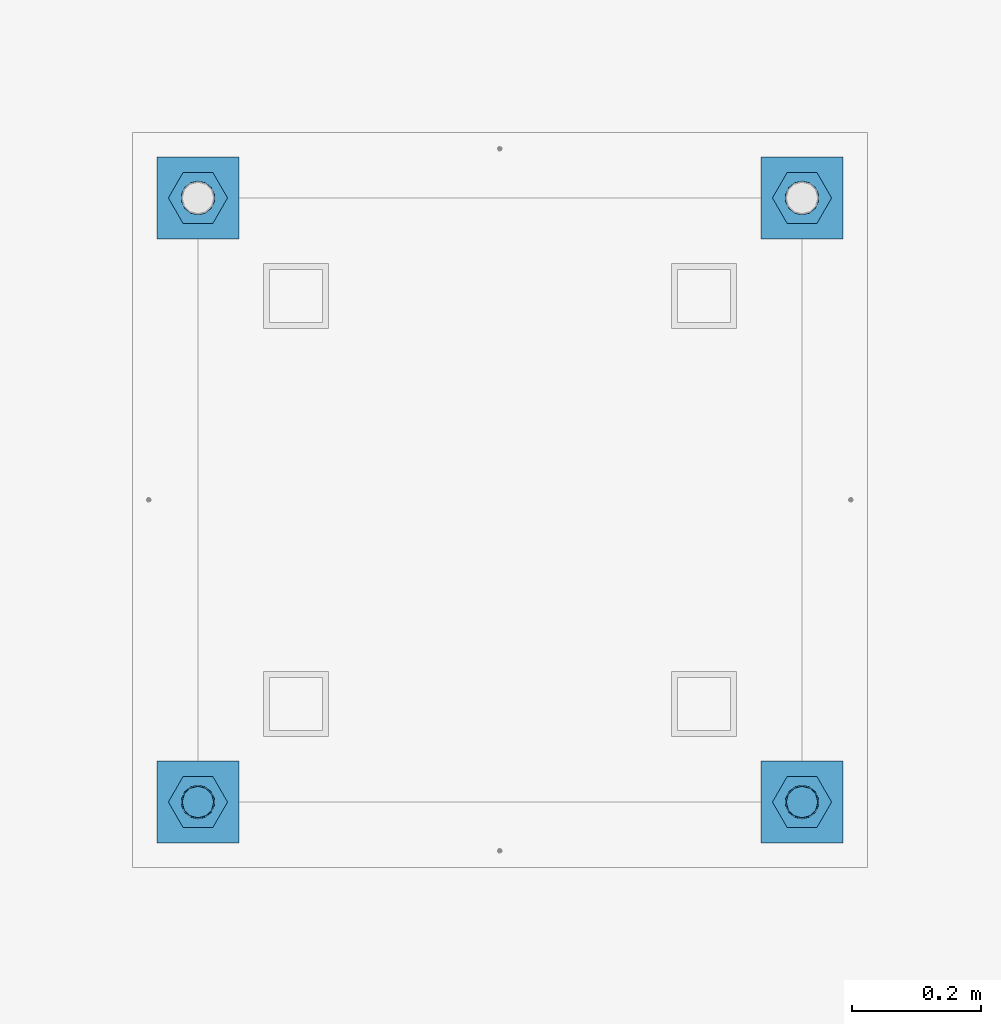
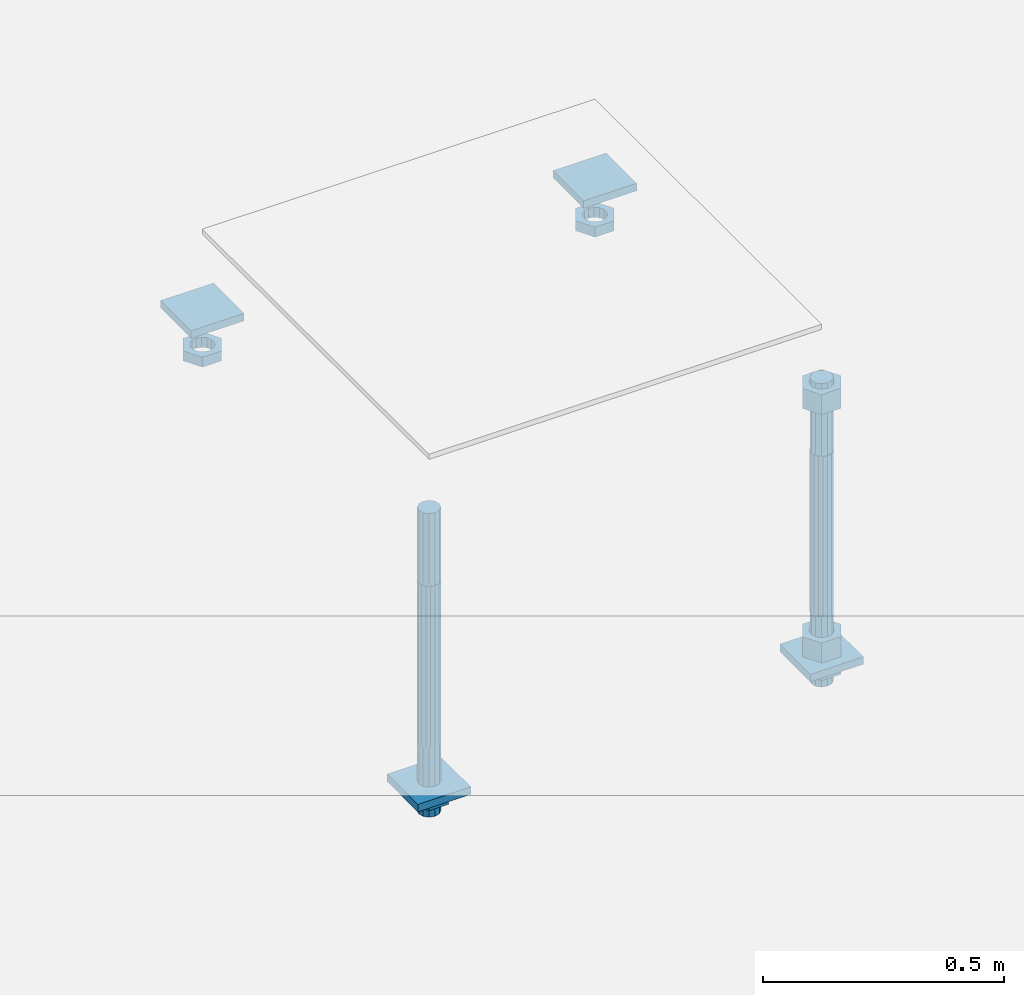
# One storey, part 2582 of 3843: 12 beams, 1 element without a shape of its own.
"""IFC2X3 building model written with IfcOpenShell, lengths in millimetres."""

from ifc_helpers import new_model, si_unit, frame, origin_with_axes, place, context, subcontext, project, spatial, faceted_brep, material, type_object, element, aggregate, save


model = new_model("IFC2X3")

# Units and contexts
model_context = context("Model", 3, precision=1e-05, world=origin_with_axes())
body_context = subcontext(model_context, "Body", "Model", "MODEL_VIEW")
ifc_project = project(units=[si_unit("LENGTHUNIT", "METRE", prefix="MILLI"), si_unit("AREAUNIT", "SQUARE_METRE"), si_unit("VOLUMEUNIT", "CUBIC_METRE"), si_unit("MASSUNIT", "GRAM", prefix="KILO"), si_unit("TIMEUNIT", "SECOND"), si_unit("PLANEANGLEUNIT", "RADIAN"), si_unit("SOLIDANGLEUNIT", "STERADIAN"), si_unit("THERMODYNAMICTEMPERATUREUNIT", "DEGREE_CELSIUS"), si_unit("LUMINOUSINTENSITYUNIT", "LUMEN")], contexts=[model_context])

# Site, building, storey
site_placement = place(None, origin_with_axes())
site = spatial("IfcSite", under=ifc_project, at=site_placement, CompositionType="ELEMENT")
building_placement = place(site_placement, origin_with_axes())
building = spatial("IfcBuilding", under=site, at=building_placement, Name="Undefined", CompositionType="ELEMENT")
storey_placement = place(building_placement, origin_with_axes())
storey = spatial("IfcBuildingStorey", under=building, at=storey_placement, Name="Undefined", CompositionType="ELEMENT", Elevation=0.0)

# Assembly, beams
assembly_placement = place(storey_placement, origin_with_axes())
assembly = element("IfcElementAssembly", 1, at=assembly_placement, inside=storey, Name="TEMPLATE", AssemblyPlace="NOTDEFINED", PredefinedType="RIGID_FRAME")
ifc_material_1 = material(Name="STEEL/A36")
beam_type_1 = type_object("IfcBeamType", PredefinedType="NOTDEFINED")
beam_1_placement = place(assembly_placement, frame((108483.4, 15176.5000015259, 29873.575), z_axis=(1.0, 0.0, 0.0), x_axis=(0.0, 1.0, 0.0)))
beam_1 = element("IfcBeam", 2, at=beam_1_placement, type_object=beam_type_1, material=ifc_material_1, Name="WASHER_PLATE", context=body_context, shape_type="Brep", body=[
    faceted_brep([(0.0, 9.52500000000146, -63.5), (0.0, 9.52500000000146, 63.5), (127.0, 9.52500000000146, 63.5), (127.0, 9.52500000000146, -63.5), (0.0, -9.52500000000146, 63.5), (127.0, -9.52500000000146, 63.5), (0.0, -9.52500000000146, -63.5), (127.0, -9.52500000000146, -63.5)], [[[0, 1, 2, 3]], [[1, 4, 5, 2]], [[4, 6, 7, 5]], [[6, 0, 3, 7]], [[5, 7, 3, 2]], [[6, 4, 1, 0]]]),
])
beam_2_placement = place(assembly_placement, frame((109423.2, 15176.5000015259, 29873.575), z_axis=(1.0, 0.0, 0.0), x_axis=(0.0, 1.0, 0.0)))
beam_2 = element("IfcBeam", 3, at=beam_2_placement, type_object=beam_type_1, material=ifc_material_1, Name="WASHER_PLATE", context=body_context, shape_type="Brep", body=[
    faceted_brep([(0.0, 9.52500000000146, -63.5), (0.0, 9.52500000000146, 63.5), (127.0, 9.52500000000146, 63.5), (127.0, 9.52500000000146, -63.5), (0.0, -9.52500000000146, 63.5), (127.0, -9.52500000000146, 63.5), (0.0, -9.52500000000146, -63.5), (127.0, -9.52500000000146, -63.5)], [[[0, 1, 2, 3]], [[1, 4, 5, 2]], [[4, 6, 7, 5]], [[6, 0, 3, 7]], [[5, 7, 3, 2]], [[6, 4, 1, 0]]]),
])
beam_3_placement = place(assembly_placement, frame((108483.4, 14236.7000015259, 29244.925), z_axis=(1.0, 0.0, 0.0), x_axis=(0.0, 1.0, 0.0)))
beam_3 = element("IfcBeam", 4, at=beam_3_placement, type_object=beam_type_1, material=ifc_material_1, Name="WASHER_PLATE", context=body_context, shape_type="Brep", body=[
    faceted_brep([(0.0, 9.52500000000146, -63.5), (0.0, 9.52500000000146, 63.5), (127.0, 9.52500000000146, 63.5), (127.0, 9.52500000000146, -63.5), (0.0, -9.52500000000146, 63.5), (127.0, -9.52500000000146, 63.5), (0.0, -9.52500000000146, -63.5), (127.0, -9.52500000000146, -63.5)], [[[0, 1, 2, 3]], [[1, 4, 5, 2]], [[4, 6, 7, 5]], [[6, 0, 3, 7]], [[5, 7, 3, 2]], [[6, 4, 1, 0]]]),
])
beam_4_placement = place(assembly_placement, frame((109423.2, 14236.7000015259, 29244.925), z_axis=(1.0, 0.0, 0.0), x_axis=(0.0, 1.0, 0.0)))
beam_4 = element("IfcBeam", 5, at=beam_4_placement, type_object=beam_type_1, material=ifc_material_1, Name="WASHER_PLATE", context=body_context, shape_type="Brep", body=[
    faceted_brep([(0.0, 9.52500000000146, -63.5), (0.0, 9.52500000000146, 63.5), (127.0, 9.52500000000146, 63.5), (127.0, 9.52500000000146, -63.5), (0.0, -9.52500000000146, 63.5), (127.0, -9.52500000000146, 63.5), (0.0, -9.52500000000146, -63.5), (127.0, -9.52500000000146, -63.5)], [[[0, 1, 2, 3]], [[1, 4, 5, 2]], [[4, 6, 7, 5]], [[6, 0, 3, 7]], [[5, 7, 3, 2]], [[6, 4, 1, 0]]]),
])
beam_type_2 = type_object("IfcBeamType", Name="2_HALF_NUT", PredefinedType="NOTDEFINED")
beam_5_placement = place(assembly_placement, frame((108483.4, 15240.0000015259, 29787.85), z_axis=(0.0, -1.0, 0.0), x_axis=(0.0, 0.0, -1.0)))
beam_5 = element("IfcBeam", 6, at=beam_5_placement, type_object=beam_type_2, material=ifc_material_1, Name="NUT", ObjectType="2_HALF_NUT", context=body_context, shape_type="Brep", body=[
    faceted_brep([(0.0, -46.0369987487793, 0.0), (0.0, -23.0184993743896, -39.869213104248), (25.4000000000015, -23.0184993743896, -39.869213104248), (25.4000000000015, -46.0369987487793, 0.0), (0.0, 23.0184993743896, -39.869213104248), (25.4000000000015, 23.0184993743896, -39.869213104248), (0.0, 46.0369987487793, 0.0), (25.4000000000015, 46.0369987487793, 0.0), (0.0, 23.0184993743896, 39.869213104248), (25.4000000000015, 23.0184993743896, 39.869213104248), (0.0, -23.0184993743896, 39.869213104248), (25.4000000000015, -23.0184993743896, 39.869213104248), (0.0, 0.0, 26.1940002441406), (0.0, 11.3650617044477, 23.5999013092805), (25.4000000000015, 11.3650617044477, 23.5999013092805), (25.4000000000015, 0.0, 26.1940002441406), (0.0, 20.4791109456419, 16.3316083006721), (25.4000000000015, 20.4791109456419, 16.3316083006721), (0.0, 25.5370200498292, 5.82867859874386), (25.4000000000015, 25.5370200498292, 5.82867859874386), (0.0, 25.5370200498292, -5.82867859874386), (25.4000000000015, 25.5370200498292, -5.82867859874386), (0.0, 20.4791109456419, -16.3316083006721), (25.4000000000015, 20.4791109456419, -16.3316083006721), (0.0, 11.3650617044477, -23.5999013092805), (25.4000000000015, 11.3650617044477, -23.5999013092805), (0.0, 0.0, -26.1940002441406), (25.4000000000015, 0.0, -26.1940002441406), (0.0, -11.3650617044477, -23.5999013092805), (25.4000000000015, -11.3650617044477, -23.5999013092805), (0.0, -20.4791109456419, -16.3316083006721), (25.4000000000015, -20.4791109456419, -16.3316083006721), (0.0, -25.5370200498292, -5.82867859874386), (25.4000000000015, -25.5370200498292, -5.82867859874386), (0.0, -25.5370200498292, 5.82867859874386), (25.4000000000015, -25.5370200498292, 5.82867859874386), (0.0, -20.4791109456419, 16.3316083006721), (25.4000000000015, -20.4791109456419, 16.3316083006721), (0.0, -11.3650617044477, 23.5999013092805), (25.4000000000015, -11.3650617044477, 23.5999013092805)], [[[0, 1, 2, 3]], [[1, 4, 5, 2]], [[4, 6, 7, 5]], [[6, 8, 9, 7]], [[8, 10, 11, 9]], [[10, 0, 3, 11]], [[12, 13, 14, 15]], [[13, 16, 17, 14]], [[16, 18, 19, 17]], [[18, 20, 21, 19]], [[20, 22, 23, 21]], [[22, 24, 25, 23]], [[24, 26, 27, 25]], [[26, 28, 29, 27]], [[28, 30, 31, 29]], [[30, 32, 33, 31]], [[32, 34, 35, 33]], [[34, 36, 37, 35]], [[36, 38, 39, 37]], [[38, 12, 15, 39]], [[5, 7, 9, 11, 3, 2], [17, 19, 21, 23, 25, 27, 29, 31, 33, 35, 37, 39, 15, 14]], [[10, 8, 6, 4, 1, 0], [38, 36, 34, 32, 30, 28, 26, 24, 22, 20, 18, 16, 13, 12]]]),
])
beam_6_placement = place(assembly_placement, frame((109423.2, 15240.0000015259, 29787.85), z_axis=(0.0, 1.0, 0.0), x_axis=(0.0, 0.0, -1.0)))
beam_6 = element("IfcBeam", 7, at=beam_6_placement, type_object=beam_type_2, material=ifc_material_1, Name="NUT", ObjectType="2_HALF_NUT", context=body_context, shape_type="Brep", body=[
    faceted_brep([(0.0, -46.0369987487793, 0.0), (0.0, -23.0184993743896, -39.869213104248), (25.4000000000015, -23.0184993743896, -39.869213104248), (25.4000000000015, -46.0369987487793, 0.0), (0.0, 23.0184993743896, -39.869213104248), (25.4000000000015, 23.0184993743896, -39.869213104248), (0.0, 46.0369987487793, 0.0), (25.4000000000015, 46.0369987487793, 0.0), (0.0, 23.0184993743896, 39.869213104248), (25.4000000000015, 23.0184993743896, 39.869213104248), (0.0, -23.0184993743896, 39.869213104248), (25.4000000000015, -23.0184993743896, 39.869213104248), (0.0, 0.0, 26.1940002441406), (0.0, 11.3650617044477, 23.5999013092805), (25.4000000000015, 11.3650617044477, 23.5999013092805), (25.4000000000015, 0.0, 26.1940002441406), (0.0, 20.4791109456419, 16.3316083006721), (25.4000000000015, 20.4791109456419, 16.3316083006721), (0.0, 25.5370200498292, 5.82867859874386), (25.4000000000015, 25.5370200498292, 5.82867859874386), (0.0, 25.5370200498292, -5.82867859874386), (25.4000000000015, 25.5370200498292, -5.82867859874386), (0.0, 20.4791109456419, -16.3316083006721), (25.4000000000015, 20.4791109456419, -16.3316083006721), (0.0, 11.3650617044477, -23.5999013092805), (25.4000000000015, 11.3650617044477, -23.5999013092805), (0.0, 0.0, -26.1940002441406), (25.4000000000015, 0.0, -26.1940002441406), (0.0, -11.3650617044477, -23.5999013092805), (25.4000000000015, -11.3650617044477, -23.5999013092805), (0.0, -20.4791109456419, -16.3316083006721), (25.4000000000015, -20.4791109456419, -16.3316083006721), (0.0, -25.5370200498292, -5.82867859874386), (25.4000000000015, -25.5370200498292, -5.82867859874386), (0.0, -25.5370200498292, 5.82867859874386), (25.4000000000015, -25.5370200498292, 5.82867859874386), (0.0, -20.4791109456419, 16.3316083006721), (25.4000000000015, -20.4791109456419, 16.3316083006721), (0.0, -11.3650617044477, 23.5999013092805), (25.4000000000015, -11.3650617044477, 23.5999013092805)], [[[0, 1, 2, 3]], [[1, 4, 5, 2]], [[4, 6, 7, 5]], [[6, 8, 9, 7]], [[8, 10, 11, 9]], [[10, 0, 3, 11]], [[12, 13, 14, 15]], [[13, 16, 17, 14]], [[16, 18, 19, 17]], [[18, 20, 21, 19]], [[20, 22, 23, 21]], [[22, 24, 25, 23]], [[24, 26, 27, 25]], [[26, 28, 29, 27]], [[28, 30, 31, 29]], [[30, 32, 33, 31]], [[32, 34, 35, 33]], [[34, 36, 37, 35]], [[36, 38, 39, 37]], [[38, 12, 15, 39]], [[5, 7, 9, 11, 3, 2], [17, 19, 21, 23, 25, 27, 29, 31, 33, 35, 37, 39, 15, 14]], [[10, 8, 6, 4, 1, 0], [38, 36, 34, 32, 30, 28, 26, 24, 22, 20, 18, 16, 13, 12]]]),
])
beam_7_placement = place(assembly_placement, frame((108483.4, 14300.2000015259, 29235.4), z_axis=(0.0, -1.0, 0.0), x_axis=(0.0, 0.0, -1.0)))
beam_7 = element("IfcBeam", 8, at=beam_7_placement, type_object=beam_type_2, material=ifc_material_1, Name="NUT", ObjectType="2_HALF_NUT", context=body_context, shape_type="Brep", body=[
    faceted_brep([(0.0, -46.0369987487793, 0.0), (0.0, -23.0184993743896, -39.869213104248), (25.4000000000015, -23.0184993743896, -39.869213104248), (25.4000000000015, -46.0369987487793, 0.0), (0.0, 23.0184993743896, -39.869213104248), (25.4000000000015, 23.0184993743896, -39.869213104248), (0.0, 46.0369987487793, 0.0), (25.4000000000015, 46.0369987487793, 0.0), (0.0, 23.0184993743896, 39.869213104248), (25.4000000000015, 23.0184993743896, 39.869213104248), (0.0, -23.0184993743896, 39.869213104248), (25.4000000000015, -23.0184993743896, 39.869213104248), (0.0, 0.0, 26.1940002441406), (0.0, 11.3650617044477, 23.5999013092805), (25.4000000000015, 11.3650617044477, 23.5999013092805), (25.4000000000015, 0.0, 26.1940002441406), (0.0, 20.4791109456419, 16.3316083006721), (25.4000000000015, 20.4791109456419, 16.3316083006721), (0.0, 25.5370200498292, 5.82867859874386), (25.4000000000015, 25.5370200498292, 5.82867859874386), (0.0, 25.5370200498292, -5.82867859874386), (25.4000000000015, 25.5370200498292, -5.82867859874386), (0.0, 20.4791109456419, -16.3316083006721), (25.4000000000015, 20.4791109456419, -16.3316083006721), (0.0, 11.3650617044477, -23.5999013092805), (25.4000000000015, 11.3650617044477, -23.5999013092805), (0.0, 0.0, -26.1940002441406), (25.4000000000015, 0.0, -26.1940002441406), (0.0, -11.3650617044477, -23.5999013092805), (25.4000000000015, -11.3650617044477, -23.5999013092805), (0.0, -20.4791109456419, -16.3316083006721), (25.4000000000015, -20.4791109456419, -16.3316083006721), (0.0, -25.5370200498292, -5.82867859874386), (25.4000000000015, -25.5370200498292, -5.82867859874386), (0.0, -25.5370200498292, 5.82867859874386), (25.4000000000015, -25.5370200498292, 5.82867859874386), (0.0, -20.4791109456419, 16.3316083006721), (25.4000000000015, -20.4791109456419, 16.3316083006721), (0.0, -11.3650617044477, 23.5999013092805), (25.4000000000015, -11.3650617044477, 23.5999013092805)], [[[0, 1, 2, 3]], [[1, 4, 5, 2]], [[4, 6, 7, 5]], [[6, 8, 9, 7]], [[8, 10, 11, 9]], [[10, 0, 3, 11]], [[12, 13, 14, 15]], [[13, 16, 17, 14]], [[16, 18, 19, 17]], [[18, 20, 21, 19]], [[20, 22, 23, 21]], [[22, 24, 25, 23]], [[24, 26, 27, 25]], [[26, 28, 29, 27]], [[28, 30, 31, 29]], [[30, 32, 33, 31]], [[32, 34, 35, 33]], [[34, 36, 37, 35]], [[36, 38, 39, 37]], [[38, 12, 15, 39]], [[5, 7, 9, 11, 3, 2], [17, 19, 21, 23, 25, 27, 29, 31, 33, 35, 37, 39, 15, 14]], [[10, 8, 6, 4, 1, 0], [38, 36, 34, 32, 30, 28, 26, 24, 22, 20, 18, 16, 13, 12]]]),
])
beam_8_placement = place(assembly_placement, frame((109423.2, 14300.2000015259, 29235.4), z_axis=(0.0, 1.0, 0.0), x_axis=(0.0, 0.0, -1.0)))
beam_8 = element("IfcBeam", 9, at=beam_8_placement, type_object=beam_type_2, material=ifc_material_1, Name="NUT", ObjectType="2_HALF_NUT", context=body_context, shape_type="Brep", body=[
    faceted_brep([(0.0, -46.0369987487793, 0.0), (0.0, -23.0184993743896, -39.869213104248), (25.4000000000015, -23.0184993743896, -39.869213104248), (25.4000000000015, -46.0369987487793, 0.0), (0.0, 23.0184993743896, -39.869213104248), (25.4000000000015, 23.0184993743896, -39.869213104248), (0.0, 46.0369987487793, 0.0), (25.4000000000015, 46.0369987487793, 0.0), (0.0, 23.0184993743896, 39.869213104248), (25.4000000000015, 23.0184993743896, 39.869213104248), (0.0, -23.0184993743896, 39.869213104248), (25.4000000000015, -23.0184993743896, 39.869213104248), (0.0, 0.0, 26.1940002441406), (0.0, 11.3650617044477, 23.5999013092805), (25.4000000000015, 11.3650617044477, 23.5999013092805), (25.4000000000015, 0.0, 26.1940002441406), (0.0, 20.4791109456419, 16.3316083006721), (25.4000000000015, 20.4791109456419, 16.3316083006721), (0.0, 25.5370200498292, 5.82867859874386), (25.4000000000015, 25.5370200498292, 5.82867859874386), (0.0, 25.5370200498292, -5.82867859874386), (25.4000000000015, 25.5370200498292, -5.82867859874386), (0.0, 20.4791109456419, -16.3316083006721), (25.4000000000015, 20.4791109456419, -16.3316083006721), (0.0, 11.3650617044477, -23.5999013092805), (25.4000000000015, 11.3650617044477, -23.5999013092805), (0.0, 0.0, -26.1940002441406), (25.4000000000015, 0.0, -26.1940002441406), (0.0, -11.3650617044477, -23.5999013092805), (25.4000000000015, -11.3650617044477, -23.5999013092805), (0.0, -20.4791109456419, -16.3316083006721), (25.4000000000015, -20.4791109456419, -16.3316083006721), (0.0, -25.5370200498292, -5.82867859874386), (25.4000000000015, -25.5370200498292, -5.82867859874386), (0.0, -25.5370200498292, 5.82867859874386), (25.4000000000015, -25.5370200498292, 5.82867859874386), (0.0, -20.4791109456419, 16.3316083006721), (25.4000000000015, -20.4791109456419, 16.3316083006721), (0.0, -11.3650617044477, 23.5999013092805), (25.4000000000015, -11.3650617044477, 23.5999013092805)], [[[0, 1, 2, 3]], [[1, 4, 5, 2]], [[4, 6, 7, 5]], [[6, 8, 9, 7]], [[8, 10, 11, 9]], [[10, 0, 3, 11]], [[12, 13, 14, 15]], [[13, 16, 17, 14]], [[16, 18, 19, 17]], [[18, 20, 21, 19]], [[20, 22, 23, 21]], [[22, 24, 25, 23]], [[24, 26, 27, 25]], [[26, 28, 29, 27]], [[28, 30, 31, 29]], [[30, 32, 33, 31]], [[32, 34, 35, 33]], [[34, 36, 37, 35]], [[36, 38, 39, 37]], [[38, 12, 15, 39]], [[5, 7, 9, 11, 3, 2], [17, 19, 21, 23, 25, 27, 29, 31, 33, 35, 37, 39, 15, 14]], [[10, 8, 6, 4, 1, 0], [38, 36, 34, 32, 30, 28, 26, 24, 22, 20, 18, 16, 13, 12]]]),
])
beam_type_3 = type_object("IfcBeamType", Name="2_HEAVY_HEX_NUT", PredefinedType="NOTDEFINED")
beam_9_placement = place(assembly_placement, frame((109423.2, 14300.2000015259, 29933.9), z_axis=(0.0, 1.0, 0.0), x_axis=(0.0, 0.0, -1.0)))
beam_9 = element("IfcBeam", 10, at=beam_9_placement, type_object=beam_type_3, material=ifc_material_1, Name="NUT", ObjectType="2_HEAVY_HEX_NUT", context=body_context, shape_type="Brep", body=[
    faceted_brep([(0.0, -46.0369987487793, 0.0), (0.0, -23.0184993743896, -39.869213104248), (50.7999999999993, -23.0184993743896, -39.869213104248), (50.7999999999993, -46.0369987487793, 0.0), (0.0, 23.0184993743896, -39.869213104248), (50.7999999999993, 23.0184993743896, -39.869213104248), (0.0, 46.0369987487793, 0.0), (50.7999999999993, 46.0369987487793, 0.0), (0.0, 23.0184993743896, 39.869213104248), (50.7999999999993, 23.0184993743896, 39.869213104248), (0.0, -23.0184993743896, 39.869213104248), (50.7999999999993, -23.0184993743896, 39.869213104248), (0.0, 0.0, 26.1940002441406), (0.0, 11.3650617044477, 23.5999013092805), (50.7999999999993, 11.3650617044477, 23.5999013092805), (50.7999999999993, 0.0, 26.1940002441406), (0.0, 20.4791109456419, 16.3316083006721), (50.7999999999993, 20.4791109456419, 16.3316083006721), (0.0, 25.5370200498292, 5.82867859874386), (50.7999999999993, 25.5370200498292, 5.82867859874386), (0.0, 25.5370200498292, -5.82867859874386), (50.7999999999993, 25.5370200498292, -5.82867859874386), (0.0, 20.4791109456419, -16.3316083006721), (50.7999999999993, 20.4791109456419, -16.3316083006721), (0.0, 11.3650617044477, -23.5999013092805), (50.7999999999993, 11.3650617044477, -23.5999013092805), (0.0, 0.0, -26.1940002441406), (50.7999999999993, 0.0, -26.1940002441406), (0.0, -11.3650617044477, -23.5999013092805), (50.7999999999993, -11.3650617044477, -23.5999013092805), (0.0, -20.4791109456419, -16.3316083006721), (50.7999999999993, -20.4791109456419, -16.3316083006721), (0.0, -25.5370200498292, -5.82867859874386), (50.7999999999993, -25.5370200498292, -5.82867859874386), (0.0, -25.5370200498292, 5.82867859874386), (50.7999999999993, -25.5370200498292, 5.82867859874386), (0.0, -20.4791109456419, 16.3316083006721), (50.7999999999993, -20.4791109456419, 16.3316083006721), (0.0, -11.3650617044477, 23.5999013092805), (50.7999999999993, -11.3650617044477, 23.5999013092805)], [[[0, 1, 2, 3]], [[1, 4, 5, 2]], [[4, 6, 7, 5]], [[6, 8, 9, 7]], [[8, 10, 11, 9]], [[10, 0, 3, 11]], [[12, 13, 14, 15]], [[13, 16, 17, 14]], [[16, 18, 19, 17]], [[18, 20, 21, 19]], [[20, 22, 23, 21]], [[22, 24, 25, 23]], [[24, 26, 27, 25]], [[26, 28, 29, 27]], [[28, 30, 31, 29]], [[30, 32, 33, 31]], [[32, 34, 35, 33]], [[34, 36, 37, 35]], [[36, 38, 39, 37]], [[38, 12, 15, 39]], [[5, 7, 9, 11, 3, 2], [17, 19, 21, 23, 25, 27, 29, 31, 33, 35, 37, 39, 15, 14]], [[10, 8, 6, 4, 1, 0], [38, 36, 34, 32, 30, 28, 26, 24, 22, 20, 18, 16, 13, 12]]]),
])
beam_10_placement = place(assembly_placement, frame((109423.2, 14300.2000015259, 29305.25), z_axis=(0.0, 1.0, 0.0), x_axis=(0.0, 0.0, -1.0)))
beam_10 = element("IfcBeam", 11, at=beam_10_placement, type_object=beam_type_3, material=ifc_material_1, Name="NUT", ObjectType="2_HEAVY_HEX_NUT", context=body_context, shape_type="Brep", body=[
    faceted_brep([(0.0, -46.0369987487793, 0.0), (0.0, -23.0184993743896, -39.869213104248), (50.7999999999993, -23.0184993743896, -39.869213104248), (50.7999999999993, -46.0369987487793, 0.0), (0.0, 23.0184993743896, -39.869213104248), (50.7999999999993, 23.0184993743896, -39.869213104248), (0.0, 46.0369987487793, 0.0), (50.7999999999993, 46.0369987487793, 0.0), (0.0, 23.0184993743896, 39.869213104248), (50.7999999999993, 23.0184993743896, 39.869213104248), (0.0, -23.0184993743896, 39.869213104248), (50.7999999999993, -23.0184993743896, 39.869213104248), (0.0, 0.0, 26.1940002441406), (0.0, 11.3650617044477, 23.5999013092805), (50.7999999999993, 11.3650617044477, 23.5999013092805), (50.7999999999993, 0.0, 26.1940002441406), (0.0, 20.4791109456419, 16.3316083006721), (50.7999999999993, 20.4791109456419, 16.3316083006721), (0.0, 25.5370200498292, 5.82867859874386), (50.7999999999993, 25.5370200498292, 5.82867859874386), (0.0, 25.5370200498292, -5.82867859874386), (50.7999999999993, 25.5370200498292, -5.82867859874386), (0.0, 20.4791109456419, -16.3316083006721), (50.7999999999993, 20.4791109456419, -16.3316083006721), (0.0, 11.3650617044477, -23.5999013092805), (50.7999999999993, 11.3650617044477, -23.5999013092805), (0.0, 0.0, -26.1940002441406), (50.7999999999993, 0.0, -26.1940002441406), (0.0, -11.3650617044477, -23.5999013092805), (50.7999999999993, -11.3650617044477, -23.5999013092805), (0.0, -20.4791109456419, -16.3316083006721), (50.7999999999993, -20.4791109456419, -16.3316083006721), (0.0, -25.5370200498292, -5.82867859874386), (50.7999999999993, -25.5370200498292, -5.82867859874386), (0.0, -25.5370200498292, 5.82867859874386), (50.7999999999993, -25.5370200498292, 5.82867859874386), (0.0, -20.4791109456419, 16.3316083006721), (50.7999999999993, -20.4791109456419, 16.3316083006721), (0.0, -11.3650617044477, 23.5999013092805), (50.7999999999993, -11.3650617044477, 23.5999013092805)], [[[0, 1, 2, 3]], [[1, 4, 5, 2]], [[4, 6, 7, 5]], [[6, 8, 9, 7]], [[8, 10, 11, 9]], [[10, 0, 3, 11]], [[12, 13, 14, 15]], [[13, 16, 17, 14]], [[16, 18, 19, 17]], [[18, 20, 21, 19]], [[20, 22, 23, 21]], [[22, 24, 25, 23]], [[24, 26, 27, 25]], [[26, 28, 29, 27]], [[28, 30, 31, 29]], [[30, 32, 33, 31]], [[32, 34, 35, 33]], [[34, 36, 37, 35]], [[36, 38, 39, 37]], [[38, 12, 15, 39]], [[5, 7, 9, 11, 3, 2], [17, 19, 21, 23, 25, 27, 29, 31, 33, 35, 37, 39, 15, 14]], [[10, 8, 6, 4, 1, 0], [38, 36, 34, 32, 30, 28, 26, 24, 22, 20, 18, 16, 13, 12]]]),
])
ifc_material_2 = material()
beam_type_4 = type_object("IfcBeamType", PredefinedType="NOTDEFINED")
beam_11_placement = place(assembly_placement, frame((108483.4, 14300.2000015259, 29762.45), z_axis=(0.0, -1.0, 0.0), x_axis=(0.0, 0.0, -1.0)))
beam_11 = element("IfcBeam", 12, at=beam_11_placement, type_object=beam_type_4, material=ifc_material_2, Name="ANCHOR_ROD", context=body_context, shape_type="Brep", body=[
    faceted_brep([(-184.150000000001, -21.217622392709, 12.25), (-184.150000000001, -12.2499999999854, 21.2176223927163), (-184.150000000001, 1.45519152283669e-11, 24.5), (-184.150000000001, 12.2500000000146, 21.2176223927163), (-184.150000000001, 21.2176223927381, 12.25), (-184.150000000001, 24.5000000000146, 0.0), (-184.150000000001, 21.2176223927381, -12.25), (-184.150000000001, 12.2500000000146, -21.2176223927163), (-184.150000000001, 1.45519152283669e-11, -24.5), (-184.150000000001, -12.2499999999854, -21.2176223927163), (-184.150000000001, -21.217622392709, -12.25), (-184.150000000001, -24.4999999999854, 0.0), (0.0, 24.5000000000146, 0.0), (0.0, 21.2176223927381, -12.25), (0.0, 12.2500000000146, -21.2176223927163), (0.0, 1.45519152283669e-11, -24.5), (0.0, -12.2499999999854, -21.2176223927163), (0.0, -21.217622392709, -12.25), (0.0, -24.4999999999854, 0.0), (0.0, -21.217622392709, 12.25), (0.0, -12.2499999999854, 21.2176223927163), (0.0, 1.45519152283669e-11, 24.5), (0.0, 12.2500000000146, 21.2176223927163), (0.0, 21.2176223927381, 12.25), (0.0, -23.4665401257807, 9.72015918207035), (0.0, -17.9605122421344, 17.9605122421417), (0.0, -9.72015918207762, 23.466540125788), (0.0, 0.0, 25.4000000000015), (0.0, 9.72015918207762, 23.466540125788), (0.0, 17.9605122421344, 17.9605122421417), (0.0, 23.4665401257807, 9.72015918207035), (0.0, 25.3999996185303, 0.0), (0.0, 23.4665401257807, -9.72015918207035), (0.0, 17.9605122421344, -17.9605122421417), (0.0, 9.72015918207762, -23.466540125788), (0.0, 0.0, -25.4000000000015), (0.0, -9.72015918207762, -23.466540125788), (0.0, -17.9605122421344, -17.9605122421417), (0.0, -23.4665401257807, -9.72015918207035), (0.0, -25.3999996185303, 0.0), (406.399999999998, -25.3999999999942, 0.0), (406.399999999998, -23.4665401257807, 9.72015918207035), (406.399999999998, -17.9605122421344, 17.9605122421417), (406.399999999998, -9.72015918207762, 23.466540125788), (406.399999999998, 0.0, 25.4000000000015), (406.399999999998, 9.72015918207762, 23.466540125788), (406.399999999998, 17.9605122421344, 17.9605122421417), (406.399999999998, 23.4665401257807, 9.72015918207035), (406.399999999998, 25.3999999999942, 0.0), (406.399999999998, 23.4665401257807, -9.72015918207035), (406.399999999998, 17.9605122421344, -17.9605122421417), (406.399999999998, 9.72015918207762, -23.466540125788), (406.399999999998, 0.0, -25.4000000000015), (406.399999999998, -9.72015918207762, -23.466540125788), (406.399999999998, -17.9605122421344, -17.9605122421417), (406.399999999998, -23.4665401257807, -9.72015918207035), (406.399999999998, -12.2499999999854, 21.2176223927163), (406.399999999998, 1.45519152283669e-11, 24.5), (406.399999999998, 12.2500000000146, 21.2176223927163), (406.399999999998, 21.2176223927381, 12.25), (406.399999999998, 24.5000000000146, 0.0), (406.399999999998, 21.2176223927381, -12.25), (406.399999999998, 12.2500000000146, -21.2176223927163), (406.399999999998, 1.45519152283669e-11, -24.5), (406.399999999998, -12.2499999999854, -21.2176223927163), (406.399999999998, -21.217622392709, -12.25), (406.399999999998, -24.4999999999854, 0.0), (406.399999999998, -21.217622392709, 12.25), (584.200000000001, -12.2499999999854, -21.2176223927163), (584.200000000001, 1.45519152283669e-11, -24.5), (584.200000000001, 12.2500000000146, -21.2176223927163), (584.200000000001, 21.2176223927381, -12.25), (584.200000000001, 24.5000000000146, 0.0), (584.200000000001, 21.2176223927381, 12.25), (584.200000000001, 12.2500000000146, 21.2176223927163), (584.200000000001, 1.45519152283669e-11, 24.5), (584.200000000001, -12.2499999999854, 21.2176223927163), (584.200000000001, -21.217622392709, 12.25), (584.200000000001, -24.4999999999854, 0.0), (584.200000000001, -21.217622392709, -12.25)], [[[0, 1, 2, 3, 4, 5, 6, 7, 8, 9, 10, 11]], [[6, 5, 12, 13]], [[7, 6, 13, 14]], [[8, 7, 14, 15]], [[9, 8, 15, 16]], [[10, 9, 16, 17]], [[11, 10, 17, 18]], [[0, 11, 18, 19]], [[1, 0, 19, 20]], [[2, 1, 20, 21]], [[3, 2, 21, 22]], [[4, 3, 22, 23]], [[5, 4, 23, 12]], [[24, 25, 26, 27, 28, 29, 30, 31, 32, 33, 34, 35, 36, 37, 38, 39], [22, 21, 20, 19, 18, 17, 16, 15, 14, 13, 12, 23]], [[24, 39, 40, 41]], [[25, 24, 41, 42]], [[26, 25, 42, 43]], [[27, 26, 43, 44]], [[28, 27, 44, 45]], [[29, 28, 45, 46]], [[30, 29, 46, 47]], [[31, 30, 47, 48]], [[32, 31, 48, 49]], [[33, 32, 49, 50]], [[34, 33, 50, 51]], [[35, 34, 51, 52]], [[36, 35, 52, 53]], [[37, 36, 53, 54]], [[38, 37, 54, 55]], [[39, 38, 55, 40]], [[54, 53, 52, 51, 50, 49, 48, 47, 46, 45, 44, 43, 42, 41, 40, 55], [56, 57, 58, 59, 60, 61, 62, 63, 64, 65, 66, 67]], [[68, 69, 70, 71, 72, 73, 74, 75, 76, 77, 78, 79]], [[76, 75, 57, 56]], [[77, 76, 56, 67]], [[78, 77, 67, 66]], [[79, 78, 66, 65]], [[68, 79, 65, 64]], [[69, 68, 64, 63]], [[70, 69, 63, 62]], [[71, 70, 62, 61]], [[72, 71, 61, 60]], [[73, 72, 60, 59]], [[74, 73, 59, 58]], [[75, 74, 58, 57]]]),
])
beam_12_placement = place(assembly_placement, frame((109423.2, 14300.2000015259, 29762.45), z_axis=(0.0, 1.0, 0.0), x_axis=(0.0, 0.0, -1.0)))
beam_12 = element("IfcBeam", 13, at=beam_12_placement, type_object=beam_type_4, material=ifc_material_2, Name="ANCHOR_ROD", context=body_context, shape_type="Brep", body=[
    faceted_brep([(-184.150000000001, -21.217622392709, 12.25), (-184.150000000001, -12.2499999999854, 21.2176223927163), (-184.150000000001, 1.45519152283669e-11, 24.5), (-184.150000000001, 12.2500000000146, 21.2176223927163), (-184.150000000001, 21.2176223927381, 12.25), (-184.150000000001, 24.5000000000146, 0.0), (-184.150000000001, 21.2176223927381, -12.25), (-184.150000000001, 12.2500000000146, -21.2176223927163), (-184.150000000001, 1.45519152283669e-11, -24.5), (-184.150000000001, -12.2499999999854, -21.2176223927163), (-184.150000000001, -21.217622392709, -12.25), (-184.150000000001, -24.4999999999854, 0.0), (0.0, 24.5000000000146, 0.0), (0.0, 21.2176223927381, -12.25), (0.0, 12.2500000000146, -21.2176223927163), (0.0, 1.45519152283669e-11, -24.5), (0.0, -12.2499999999854, -21.2176223927163), (0.0, -21.217622392709, -12.25), (0.0, -24.4999999999854, 0.0), (0.0, -21.217622392709, 12.25), (0.0, -12.2499999999854, 21.2176223927163), (0.0, 1.45519152283669e-11, 24.5), (0.0, 12.2500000000146, 21.2176223927163), (0.0, 21.2176223927381, 12.25), (0.0, -23.4665401257807, 9.72015918207035), (0.0, -17.9605122421344, 17.9605122421417), (0.0, -9.72015918207762, 23.466540125788), (0.0, 0.0, 25.4000000000015), (0.0, 9.72015918207762, 23.466540125788), (0.0, 17.9605122421344, 17.9605122421417), (0.0, 23.4665401257807, 9.72015918207035), (0.0, 25.3999996185303, 0.0), (0.0, 23.4665401257807, -9.72015918207035), (0.0, 17.9605122421344, -17.9605122421417), (0.0, 9.72015918207762, -23.466540125788), (0.0, 0.0, -25.4000000000015), (0.0, -9.72015918207762, -23.466540125788), (0.0, -17.9605122421344, -17.9605122421417), (0.0, -23.4665401257807, -9.72015918207035), (0.0, -25.3999996185303, 0.0), (406.399999999998, -25.3999999999942, 0.0), (406.399999999998, -23.4665401257807, 9.72015918207035), (406.399999999998, -17.9605122421344, 17.9605122421417), (406.399999999998, -9.72015918207762, 23.466540125788), (406.399999999998, 0.0, 25.4000000000015), (406.399999999998, 9.72015918207762, 23.466540125788), (406.399999999998, 17.9605122421344, 17.9605122421417), (406.399999999998, 23.4665401257807, 9.72015918207035), (406.399999999998, 25.3999999999942, 0.0), (406.399999999998, 23.4665401257807, -9.72015918207035), (406.399999999998, 17.9605122421344, -17.9605122421417), (406.399999999998, 9.72015918207762, -23.466540125788), (406.399999999998, 0.0, -25.4000000000015), (406.399999999998, -9.72015918207762, -23.466540125788), (406.399999999998, -17.9605122421344, -17.9605122421417), (406.399999999998, -23.4665401257807, -9.72015918207035), (406.399999999998, -12.2499999999854, 21.2176223927163), (406.399999999998, 1.45519152283669e-11, 24.5), (406.399999999998, 12.2500000000146, 21.2176223927163), (406.399999999998, 21.2176223927381, 12.25), (406.399999999998, 24.5000000000146, 0.0), (406.399999999998, 21.2176223927381, -12.25), (406.399999999998, 12.2500000000146, -21.2176223927163), (406.399999999998, 1.45519152283669e-11, -24.5), (406.399999999998, -12.2499999999854, -21.2176223927163), (406.399999999998, -21.217622392709, -12.25), (406.399999999998, -24.4999999999854, 0.0), (406.399999999998, -21.217622392709, 12.25), (584.200000000001, -12.2499999999854, -21.2176223927163), (584.200000000001, 1.45519152283669e-11, -24.5), (584.200000000001, 12.2500000000146, -21.2176223927163), (584.200000000001, 21.2176223927381, -12.25), (584.200000000001, 24.5000000000146, 0.0), (584.200000000001, 21.2176223927381, 12.25), (584.200000000001, 12.2500000000146, 21.2176223927163), (584.200000000001, 1.45519152283669e-11, 24.5), (584.200000000001, -12.2499999999854, 21.2176223927163), (584.200000000001, -21.217622392709, 12.25), (584.200000000001, -24.4999999999854, 0.0), (584.200000000001, -21.217622392709, -12.25)], [[[0, 1, 2, 3, 4, 5, 6, 7, 8, 9, 10, 11]], [[6, 5, 12, 13]], [[7, 6, 13, 14]], [[8, 7, 14, 15]], [[9, 8, 15, 16]], [[10, 9, 16, 17]], [[11, 10, 17, 18]], [[0, 11, 18, 19]], [[1, 0, 19, 20]], [[2, 1, 20, 21]], [[3, 2, 21, 22]], [[4, 3, 22, 23]], [[5, 4, 23, 12]], [[24, 25, 26, 27, 28, 29, 30, 31, 32, 33, 34, 35, 36, 37, 38, 39], [22, 21, 20, 19, 18, 17, 16, 15, 14, 13, 12, 23]], [[24, 39, 40, 41]], [[25, 24, 41, 42]], [[26, 25, 42, 43]], [[27, 26, 43, 44]], [[28, 27, 44, 45]], [[29, 28, 45, 46]], [[30, 29, 46, 47]], [[31, 30, 47, 48]], [[32, 31, 48, 49]], [[33, 32, 49, 50]], [[34, 33, 50, 51]], [[35, 34, 51, 52]], [[36, 35, 52, 53]], [[37, 36, 53, 54]], [[38, 37, 54, 55]], [[39, 38, 55, 40]], [[54, 53, 52, 51, 50, 49, 48, 47, 46, 45, 44, 43, 42, 41, 40, 55], [56, 57, 58, 59, 60, 61, 62, 63, 64, 65, 66, 67]], [[68, 69, 70, 71, 72, 73, 74, 75, 76, 77, 78, 79]], [[76, 75, 57, 56]], [[77, 76, 56, 67]], [[78, 77, 67, 66]], [[79, 78, 66, 65]], [[68, 79, 65, 64]], [[69, 68, 64, 63]], [[70, 69, 63, 62]], [[71, 70, 62, 61]], [[72, 71, 61, 60]], [[73, 72, 60, 59]], [[74, 73, 59, 58]], [[75, 74, 58, 57]]]),
])
aggregate(assembly, [beam_5, beam_6, beam_1, beam_2, beam_7, beam_3, beam_11, beam_9, beam_10, beam_8, beam_4, beam_12])

save(model, "model.ifc")
